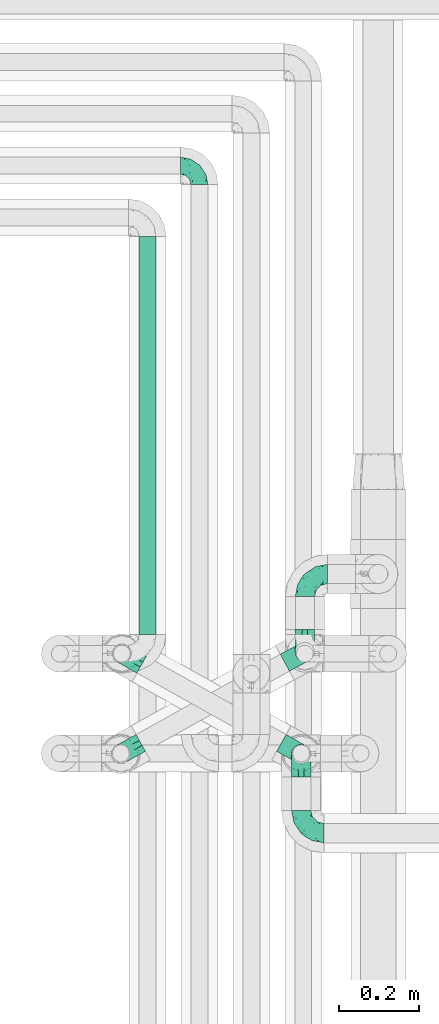
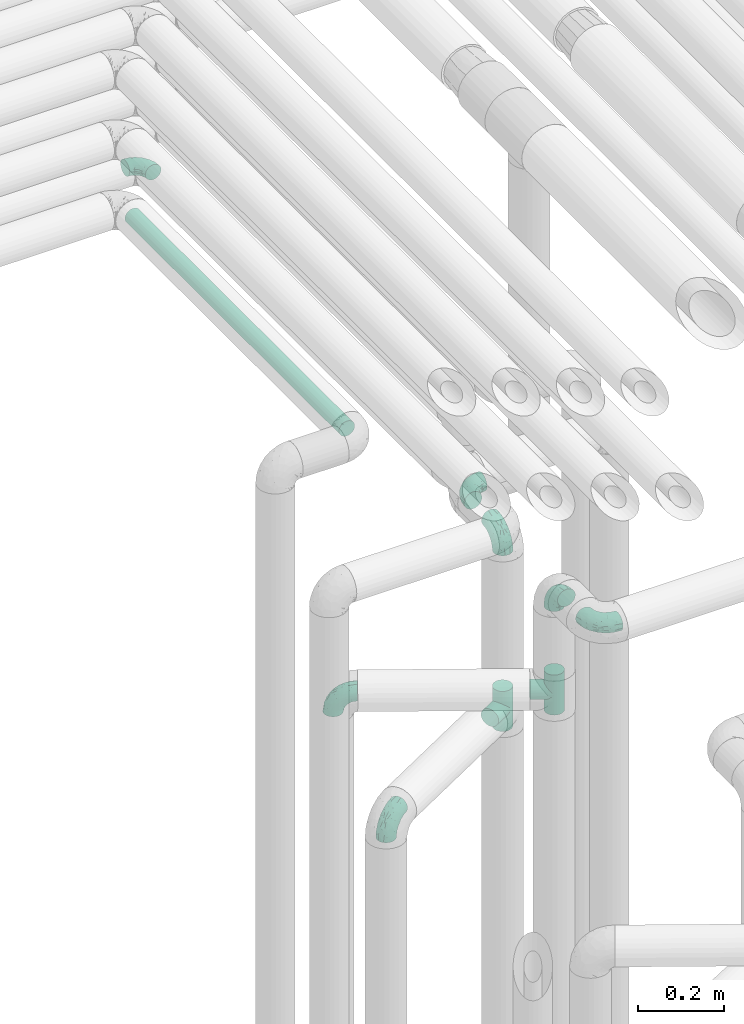
# One storey, part 602 of 827: 9 flow fittings, 1 flow segment.
"""IFC2X3 building model written with IfcOpenShell, lengths in millimetres."""

from ifc_helpers import new_model, entity, si_unit, converted_unit, derived_unit, direction, frame, origin, origin_2d_with_axis, place, context, subcontext, project, spatial, circle, extrude, faceted_brep, source, transform, mapped, material, type_object, type_shapes, element, save


model = new_model("IFC2X3")

# Units and contexts
model_context = context("Model", 3, precision=0.01, world=origin(), true_north=direction((6.12303176911189e-17, 1.0)))
body_context = subcontext(model_context, "Body", "Model", "MODEL_VIEW")
ifc_project = project(units=[si_unit("LENGTHUNIT", "METRE", prefix="MILLI"), si_unit("AREAUNIT", "SQUARE_METRE"), si_unit("VOLUMEUNIT", "CUBIC_METRE"), converted_unit("PLANEANGLEUNIT", "DEGREE", entity("IfcRatioMeasure", 0.0174532925199433), si_unit("PLANEANGLEUNIT", "RADIAN"), dimensions=[0, 0, 0, 0, 0, 0, 0]), si_unit("MASSUNIT", "GRAM", prefix="KILO"), derived_unit("MASSDENSITYUNIT", [(si_unit("MASSUNIT", "GRAM", prefix="KILO"), 1), (si_unit("LENGTHUNIT", "METRE"), -3)]), derived_unit("MOMENTOFINERTIAUNIT", [(si_unit("LENGTHUNIT", "METRE"), 4)]), si_unit("TIMEUNIT", "SECOND"), si_unit("FREQUENCYUNIT", "HERTZ"), si_unit("THERMODYNAMICTEMPERATUREUNIT", "DEGREE_CELSIUS"), derived_unit("THERMALTRANSMITTANCEUNIT", [(si_unit("MASSUNIT", "GRAM", prefix="KILO"), 1), (si_unit("THERMODYNAMICTEMPERATUREUNIT", "KELVIN"), -1), (si_unit("TIMEUNIT", "SECOND"), -3)]), derived_unit("VOLUMETRICFLOWRATEUNIT", [(si_unit("LENGTHUNIT", "METRE"), 3), (si_unit("TIMEUNIT", "SECOND"), -1)]), derived_unit("MASSFLOWRATEUNIT", [(si_unit("MASSUNIT", "GRAM", prefix="KILO"), 1), (si_unit("TIMEUNIT", "SECOND"), -1)]), derived_unit("ROTATIONALFREQUENCYUNIT", [(si_unit("TIMEUNIT", "SECOND"), -1)]), si_unit("ELECTRICCURRENTUNIT", "AMPERE"), si_unit("ELECTRICVOLTAGEUNIT", "VOLT"), si_unit("POWERUNIT", "WATT"), si_unit("FORCEUNIT", "NEWTON", prefix="KILO"), si_unit("ILLUMINANCEUNIT", "LUX"), si_unit("LUMINOUSFLUXUNIT", "LUMEN"), si_unit("LUMINOUSINTENSITYUNIT", "CANDELA"), derived_unit("USERDEFINED", [(si_unit("MASSUNIT", "GRAM", prefix="KILO"), -1), (si_unit("LENGTHUNIT", "METRE"), -2), (si_unit("TIMEUNIT", "SECOND"), 3), (si_unit("LUMINOUSFLUXUNIT", "LUMEN"), 1)]), derived_unit("LINEARVELOCITYUNIT", [(si_unit("LENGTHUNIT", "METRE"), 1), (si_unit("TIMEUNIT", "SECOND"), -1)]), si_unit("PRESSUREUNIT", "PASCAL"), derived_unit("USERDEFINED", [(si_unit("LENGTHUNIT", "METRE"), -2), (si_unit("MASSUNIT", "GRAM", prefix="KILO"), 1), (si_unit("TIMEUNIT", "SECOND"), -2)]), derived_unit("LINEARFORCEUNIT", [(si_unit("MASSUNIT", "GRAM", prefix="KILO"), 1), (si_unit("LENGTHUNIT", "METRE"), 1), (si_unit("TIMEUNIT", "SECOND"), -2), (si_unit("LENGTHUNIT", "METRE"), -1)]), derived_unit("PLANARFORCEUNIT", [(si_unit("MASSUNIT", "GRAM", prefix="KILO"), 1), (si_unit("LENGTHUNIT", "METRE"), 1), (si_unit("TIMEUNIT", "SECOND"), -2), (si_unit("LENGTHUNIT", "METRE"), -2)])], contexts=[model_context])

# Site, building, storey
site_placement = place(None, origin())
site = spatial("IfcSite", under=ifc_project, at=site_placement, CompositionType="ELEMENT")
building_placement = place(site_placement, origin())
building = spatial("IfcBuilding", under=site, at=building_placement, CompositionType="ELEMENT")
storey_placement = place(building_placement, frame((0.0, 0.0, 28200.0)))
storey = spatial("IfcBuildingStorey", under=building, at=storey_placement, Name="08", CompositionType="ELEMENT", Elevation=28200.0)

# Flow segment
pipe_segment_type = type_object("IfcPipeSegmentType", PredefinedType="NOTDEFINED")
flow_segment_placement = place(storey_placement, frame((35317.29, 13054.2, 2977.25)))
element("IfcFlowSegment", 1, at=flow_segment_placement, inside=storey, type_object=pipe_segment_type, context=body_context, shape_type="SweptSolid", body=[
    extrude(circle(Radius=21.15, at=origin_2d_with_axis()), frame((22.75, 0.0, 22.75), z_axis=(0.0, 1.0, 0.0), x_axis=(-1.0, 0.0, 0.0)), (0.0, 0.0, 1.0), 997.797074054168),
])

# Flow fittings
ifc_material = material()
pipe_fitting_type_1 = type_object("IfcPipeFittingType", Name="ADSK_1", PredefinedType="NOTDEFINED", material=ifc_material)
shared_shape_1 = source(origin(), body_context, "Body", "Brep", [
    faceted_brep([(-57.0, 12.07, -20.91), (-57.0, 6.25, -23.33), (-57.0, 0.0, -24.15), (-57.0, -6.25, -23.33), (-57.0, -12.08, -20.91), (-57.0, -17.08, -17.08), (-57.0, -20.91, -12.08), (-57.0, -23.33, -6.25), (-57.0, -24.15, 0.0), (-57.0, -23.33, 6.25), (-57.0, -20.91, 12.07), (-57.0, -17.08, 17.08), (-57.0, -12.08, 20.91), (-57.0, -6.25, 23.33), (-57.0, 0.0, 24.15), (-57.0, 6.25, 23.33), (-57.0, 12.07, 20.91), (-57.0, 17.08, 17.08), (-57.0, 20.91, 12.07), (-57.0, 23.33, 6.25), (-57.0, 24.15, 0.0), (-57.0, 23.33, -6.25), (-57.0, 20.91, -12.08), (-57.0, 17.08, -17.08), (0.0, 57.0, -24.15), (-6.25, 57.0, -23.33), (-12.07, 57.0, -20.91), (-17.08, 57.0, -17.08), (-20.91, 57.0, -12.08), (-23.33, 57.0, -6.25), (-24.15, 57.0, 0.0), (-23.33, 57.0, 6.25), (-20.91, 57.0, 12.07), (-17.08, 57.0, 17.08), (-12.07, 57.0, 20.91), (-6.25, 57.0, 23.33), (0.0, 57.0, 24.15), (6.25, 57.0, 23.33), (12.08, 57.0, 20.91), (17.08, 57.0, 17.08), (20.91, 57.0, 12.07), (23.33, 57.0, 6.25), (24.15, 57.0, 0.0), (23.33, 57.0, -6.25), (20.91, 57.0, -12.08), (17.08, 57.0, -17.08), (12.08, 57.0, -20.91), (6.25, 57.0, -23.33), (14.9, 21.14, 6.17), (13.61, 24.64, 12.48), (6.23, 8.95, 8.98), (-41.47, -21.06, 0.0), (-41.92, -18.38, 13.72), (-24.64, -13.61, 12.48), (-37.37, -13.24, 18.15), (-6.8, -4.93, 8.18), (-21.76, -15.19, 6.22), (-12.78, -9.18, 0.0), (-37.73, -20.51, 7.75), (-7.38, 7.38, 20.24), (-23.37, -4.26, 20.42), (-11.9, -3.19, 15.86), (-42.14, -8.7, 21.82), (13.24, 37.37, 18.15), (9.33, 23.53, 16.85), (4.26, 23.37, 20.42), (2.77, 10.92, 15.55), (-29.46, 0.91, 23.52), (-44.13, 20.56, 15.69), (-39.25, 26.33, 10.88), (-49.02, 22.92, 9.96), (-34.58, 23.87, 17.15), (-15.8, 6.8, 22.81), (-8.67, 20.47, 23.88), (-18.12, 12.9, 24.08), (-48.29, 14.92, 19.65), (-44.06, -2.85, 23.78), (-9.23, 48.95, 22.58), (-3.78, 42.74, 24.07), (-40.34, 4.26, 24.09), (-44.02, 26.14, 5.46), (-44.04, 9.88, 22.74), (-4.95, 16.87, 22.52), (-2.75, 1.43, 12.5), (-25.48, 40.98, 10.71), (20.51, 37.73, 7.75), (18.38, 41.92, 13.72), (8.7, 42.14, 21.82), (-25.95, -17.97, 0.0), (2.85, 44.06, 23.78), (21.06, 41.47, 0.0), (17.97, 25.95, 0.0), (-24.04, -9.27, 17.13), (-33.26, 33.26, 5.86), (-28.55, 40.57, 0.0), (-40.57, 28.55, 0.0), (-25.29, 47.19, 4.06), (-27.01, 31.1, 16.77), (-15.7, 43.95, 19.9), (-20.27, 45.22, 15.61), (-30.53, 31.98, 12.64), (-11.28, 38.33, 22.92), (-9.97, 27.88, 24.09), (-20.15, 30.26, 21.25), (-31.25, 11.75, 23.64), (-28.75, 7.23, 24.15), (-29.53, 18.06, 22.27), (-28.44, 24.21, 20.02), (-37.55, 17.7, 20.26), (-15.88, 29.25, 22.99), (-20.82, 20.82, 23.44), (-0.91, 29.46, 23.52), (-13.5, -7.67, 12.04), (1.49, 1.56, 5.16), (8.86, 10.35, 4.59), (0.38, -0.38, 0.0), (9.18, 12.78, 0.0), (-37.37, -13.24, -18.15), (8.86, 10.35, -4.59), (-45.22, 20.27, -15.61), (-43.95, 15.7, -19.9), (-38.33, 11.28, -22.92), (-48.95, 9.23, -22.58), (-47.19, 25.29, -4.06), (-33.26, 33.26, -5.86), (18.38, 41.92, -13.72), (-30.26, 20.15, -21.25), (2.85, 44.06, -23.78), (-4.26, 40.34, -24.09), (-40.98, 25.48, -10.71), (-41.92, -18.38, -13.72), (9.25, 23.5, -16.92), (4.26, 23.37, -20.42), (13.24, 37.37, -18.15), (-37.73, -20.51, -7.75), (-11.75, 31.25, -23.64), (-7.23, 28.75, -24.15), (-12.9, 18.12, -24.08), (8.7, 42.14, -21.82), (-44.06, -2.85, -23.78), (-6.8, 15.8, -22.81), (-20.47, 8.67, -23.88), (-24.64, -13.61, -12.48), (-42.74, 3.78, -24.07), (-18.06, 29.53, -22.27), (-24.21, 28.44, -20.02), (-27.88, 9.97, -24.09), (-31.1, 27.01, -16.77), (-26.14, 44.02, -5.46), (14.9, 21.14, -6.17), (20.51, 37.73, -7.75), (-9.88, 44.04, -22.74), (-20.56, 44.13, -15.69), (-21.76, -15.19, -6.22), (-13.5, -7.67, -12.04), (-24.14, -9.76, -16.74), (-11.9, -3.19, -15.86), (-14.92, 48.29, -19.65), (-23.37, -4.26, -20.42), (-0.91, 29.46, -23.52), (-26.33, 39.25, -10.88), (-23.87, 34.58, -17.15), (-42.14, -8.7, -21.82), (-22.92, 49.02, -9.96), (13.61, 24.64, -12.48), (-31.98, 30.53, -12.64), (-16.87, 4.95, -22.52), (-17.7, 37.55, -20.26), (-29.25, 15.88, -22.99), (-20.82, 20.82, -23.44), (-29.46, 0.91, -23.52), (-7.38, 7.38, -20.24), (2.77, 10.92, -15.55), (6.23, 8.95, -8.98), (-6.8, -4.93, -8.18), (-2.81, 1.41, -12.54), (1.49, 1.56, -5.16)], [[[0, 1, 2, 3, 4, 5, 6, 7, 8, 9, 10, 11, 12, 13, 14, 15, 16, 17, 18, 19, 20, 21, 22, 23]], [[24, 25, 26, 27, 28, 29, 30, 31, 32, 33, 34, 35, 36, 37, 38, 39, 40, 41, 42, 43, 44, 45, 46, 47]], [[48, 49, 50]], [[9, 8, 51]], [[52, 53, 54]], [[55, 56, 57]], [[10, 58, 52]], [[9, 58, 10]], [[59, 60, 61]], [[54, 12, 11]], [[54, 62, 12]], [[63, 39, 38]], [[64, 65, 66]], [[62, 60, 67]], [[68, 69, 70]], [[71, 69, 68]], [[72, 73, 74]], [[16, 75, 17]], [[13, 76, 14]], [[35, 77, 78]], [[14, 79, 15]], [[17, 68, 18]], [[14, 76, 79]], [[20, 19, 80]], [[70, 19, 18]], [[81, 15, 79]], [[15, 81, 16]], [[73, 72, 82]], [[66, 83, 50]], [[32, 31, 84]], [[85, 86, 49]], [[63, 87, 65]], [[56, 58, 88]], [[36, 89, 37]], [[85, 41, 40]], [[36, 35, 78]], [[90, 41, 85]], [[40, 39, 86]], [[12, 62, 13]], [[86, 85, 40]], [[48, 85, 49]], [[85, 91, 90]], [[87, 38, 37]], [[92, 60, 54]], [[80, 69, 93]], [[93, 94, 95]], [[10, 52, 11]], [[94, 96, 30]], [[97, 98, 99]], [[80, 93, 95]], [[100, 97, 84]], [[99, 98, 33]], [[101, 102, 78]], [[103, 101, 98]], [[96, 31, 30]], [[77, 98, 101]], [[77, 35, 34]], [[34, 33, 98]], [[9, 51, 58]], [[87, 63, 38]], [[104, 105, 74]], [[106, 103, 107]], [[106, 81, 104]], [[75, 68, 17]], [[108, 107, 71]], [[33, 32, 99]], [[109, 103, 110]], [[101, 109, 102]], [[89, 78, 111]], [[53, 52, 58]], [[54, 11, 52]], [[60, 62, 54]], [[88, 58, 51]], [[76, 62, 67]], [[53, 112, 92]], [[60, 59, 72]], [[39, 63, 86]], [[49, 86, 63]], [[89, 87, 37]], [[42, 41, 90]], [[111, 82, 65]], [[111, 65, 87]], [[65, 59, 66]], [[104, 81, 79]], [[75, 81, 108]], [[32, 84, 99]], [[97, 99, 84]], [[98, 97, 103]], [[106, 107, 108]], [[74, 102, 110]], [[111, 78, 102]], [[74, 110, 104]], [[74, 67, 72]], [[61, 92, 112]], [[66, 59, 61]], [[56, 53, 58]], [[66, 50, 49]], [[61, 112, 83]], [[66, 49, 64]], [[78, 89, 36]], [[87, 89, 111]], [[62, 76, 13]], [[79, 76, 67]], [[100, 93, 69]], [[96, 93, 84]], [[55, 113, 50]], [[113, 114, 50]], [[104, 79, 105]], [[106, 104, 110]], [[20, 80, 95]], [[85, 48, 91]], [[115, 114, 113]], [[116, 91, 48]], [[70, 80, 19]], [[93, 96, 94]], [[84, 31, 96]], [[103, 106, 110]], [[81, 106, 108]], [[103, 97, 107]], [[71, 107, 97]], [[71, 97, 100]], [[108, 71, 68]], [[79, 67, 105]], [[67, 74, 105]], [[115, 113, 57]], [[112, 56, 55]], [[56, 88, 57]], [[60, 72, 67]], [[82, 72, 59]], [[65, 82, 59]], [[82, 111, 73]], [[111, 102, 73]], [[102, 74, 73]], [[81, 75, 16]], [[68, 75, 108]], [[68, 70, 18]], [[80, 70, 69]], [[98, 77, 34]], [[78, 77, 101]], [[93, 100, 84]], [[71, 100, 69]], [[102, 109, 110]], [[101, 103, 109]], [[53, 92, 54]], [[61, 60, 92]], [[56, 112, 53]], [[83, 112, 55]], [[50, 83, 55]], [[61, 83, 66]], [[49, 63, 64]], [[65, 64, 63]], [[57, 113, 55]], [[114, 115, 116]], [[116, 48, 114]], [[48, 50, 114]], [[117, 5, 4]], [[116, 115, 118]], [[119, 120, 23]], [[121, 122, 120]], [[95, 123, 20]], [[0, 23, 120]], [[124, 95, 94]], [[125, 45, 44]], [[121, 120, 126]], [[24, 127, 128]], [[22, 21, 129]], [[0, 122, 1]], [[5, 117, 130]], [[131, 132, 133]], [[134, 88, 51]], [[135, 136, 137]], [[6, 5, 130]], [[46, 138, 47]], [[139, 3, 2]], [[140, 141, 137]], [[6, 134, 7]], [[134, 130, 142]], [[143, 2, 1]], [[144, 126, 145]], [[121, 146, 143]], [[147, 120, 119]], [[94, 148, 124]], [[149, 150, 91]], [[30, 29, 148]], [[151, 25, 128]], [[27, 152, 28]], [[134, 153, 88]], [[154, 155, 156]], [[27, 26, 157]], [[151, 26, 25]], [[155, 158, 156]], [[24, 47, 127]], [[1, 122, 143]], [[138, 132, 159]], [[160, 152, 161]], [[24, 128, 25]], [[46, 133, 138]], [[162, 117, 4]], [[148, 160, 124]], [[152, 160, 163]], [[154, 142, 155]], [[45, 125, 133]], [[133, 46, 45]], [[125, 164, 133]], [[51, 7, 134]], [[42, 90, 43]], [[165, 147, 129]], [[153, 134, 142]], [[43, 150, 44]], [[162, 4, 3]], [[141, 140, 166]], [[117, 162, 158]], [[163, 29, 28]], [[43, 90, 150]], [[123, 21, 20]], [[144, 151, 135]], [[157, 152, 27]], [[167, 145, 161]], [[23, 22, 119]], [[168, 126, 169]], [[121, 168, 146]], [[139, 143, 170]], [[142, 130, 117]], [[8, 7, 51]], [[134, 6, 130]], [[139, 162, 3]], [[170, 166, 158]], [[170, 158, 162]], [[158, 171, 156]], [[44, 150, 125]], [[91, 150, 90]], [[164, 125, 150]], [[132, 138, 133]], [[127, 138, 159]], [[131, 164, 172]], [[132, 171, 140]], [[135, 151, 128]], [[157, 151, 167]], [[22, 129, 119]], [[147, 119, 129]], [[120, 147, 126]], [[144, 145, 167]], [[137, 146, 169]], [[170, 143, 146]], [[137, 169, 135]], [[137, 159, 140]], [[171, 172, 156]], [[173, 174, 175]], [[156, 175, 154]], [[174, 57, 153]], [[132, 172, 171]], [[172, 164, 173]], [[143, 139, 2]], [[162, 139, 170]], [[138, 127, 47]], [[128, 127, 159]], [[165, 124, 160]], [[123, 124, 129]], [[149, 173, 164]], [[176, 174, 173]], [[135, 128, 136]], [[144, 135, 169]], [[150, 149, 164]], [[176, 118, 115]], [[149, 91, 116]], [[30, 148, 94]], [[163, 148, 29]], [[124, 123, 95]], [[129, 21, 123]], [[126, 144, 169]], [[151, 144, 167]], [[126, 147, 145]], [[161, 145, 147]], [[161, 147, 165]], [[167, 161, 152]], [[128, 159, 136]], [[159, 137, 136]], [[154, 153, 142]], [[132, 140, 159]], [[174, 176, 57]], [[57, 88, 153]], [[166, 140, 171]], [[158, 166, 171]], [[166, 170, 141]], [[170, 146, 141]], [[146, 137, 141]], [[151, 157, 26]], [[152, 157, 167]], [[152, 163, 28]], [[148, 163, 160]], [[120, 122, 0]], [[143, 122, 121]], [[124, 165, 129]], [[161, 165, 160]], [[146, 168, 169]], [[121, 126, 168]], [[142, 117, 155]], [[158, 155, 117]], [[175, 156, 172]], [[153, 154, 174]], [[173, 175, 172]], [[174, 154, 175]], [[164, 131, 133]], [[172, 132, 131]], [[176, 173, 118]], [[57, 176, 115]], [[173, 149, 118]], [[149, 116, 118]]]),
])
type_shapes(pipe_fitting_type_1, [shared_shape_1])
for number, where, z_axis, x_axis, name in (
    (2, (35734.24, 13010.49, 2600.0), (-1.0, 0.0, 0.0), (0.0, 0.0, 1.0), "ADSK_1"),
    (3, (35734.24, 13206.08, 2600.0), (0.0, 0.0, 1.0), (-1.0, 0.0, 0.0), "ADSK_1"),
    (4, (35725.03, 12754.46, 2600.0), (1.0, 0.0, 0.0), (0.0, 0.0, 1.0), "ADSK_1"),
    (5, (35725.03, 12556.08, 2600.0), (0.0, 0.0, 1.0), (0.0, -1.0, 0.0), "ADSK_1"),
    (6, (35275.34, 13006.53, 2305.0), (-0.488239231862421, -0.872709832917215, 0.0), (-0.872709832917215, 0.488239231862421, 0.0), "ADSK_1"),
    (7, (35272.9, 12754.86, 2100.0), (0.486104408033654, -0.873900740639491, 0.0), (-0.873900740639491, -0.486104408033654, 0.0), "ADSK_1"),
):
    element("IfcFlowFitting", number, at=place(storey_placement, frame(where, z_axis=z_axis, x_axis=x_axis)), inside=storey, type_object=pipe_fitting_type_1, material=ifc_material, Name=name, ObjectType="ADSK_1", context=body_context, shape_type="MappedRepresentation", body=[
        mapped(shared_shape_1, transform((0.0, 0.0, 0.0), scale=1.0)),
    ])
pipe_fitting_type_2 = type_object("IfcPipeFittingType", Name="ADSK_1", PredefinedType="NOTDEFINED", material=ifc_material)
shared_shape_2 = source(origin(), body_context, "Body", "Brep", [
    faceted_brep([(-48.0, 10.6, -18.36), (-48.0, 5.49, -20.48), (-48.0, 0.0, -21.2), (-48.0, -5.49, -20.48), (-48.0, -10.6, -18.36), (-48.0, -14.99, -14.99), (-48.0, -18.36, -10.6), (-48.0, -20.48, -5.49), (-48.0, -21.2, 0.0), (-48.0, -20.48, 5.49), (-48.0, -18.36, 10.6), (-48.0, -14.99, 14.99), (-48.0, -10.6, 18.36), (-48.0, -5.49, 20.48), (-48.0, 0.0, 21.2), (-48.0, 5.49, 20.48), (-48.0, 10.6, 18.36), (-48.0, 14.99, 14.99), (-48.0, 18.36, 10.6), (-48.0, 20.48, 5.49), (-48.0, 21.2, 0.0), (-48.0, 20.48, -5.49), (-48.0, 18.36, -10.6), (-48.0, 14.99, -14.99), (0.0, 48.0, -21.2), (-5.49, 48.0, -20.48), (-10.6, 48.0, -18.36), (-14.99, 48.0, -14.99), (-18.36, 48.0, -10.6), (-20.48, 48.0, -5.49), (-21.2, 48.0, 0.0), (-20.48, 48.0, 5.49), (-18.36, 48.0, 10.6), (-14.99, 48.0, 14.99), (-10.6, 48.0, 18.36), (-5.49, 48.0, 20.48), (0.0, 48.0, 21.2), (5.49, 48.0, 20.48), (10.6, 48.0, 18.36), (14.99, 48.0, 14.99), (18.36, 48.0, 10.6), (20.48, 48.0, 5.49), (21.2, 48.0, 0.0), (20.48, 48.0, -5.49), (18.36, 48.0, -10.6), (14.99, 48.0, -14.99), (10.6, 48.0, -18.36), (5.49, 48.0, -20.48), (-35.25, -16.22, 12.01), (-34.76, -18.57, 0.0), (-20.87, -12.37, 10.9), (-31.49, -11.78, 15.9), (-37.0, -2.58, 20.86), (-33.89, 3.62, 21.15), (-31.81, -18.14, 6.76), (-5.78, 5.78, 17.67), (-19.42, -4.1, 17.86), (-9.6, -3.39, 13.73), (-35.44, -7.73, 19.13), (11.78, 31.49, 15.9), (-5.93, -5.46, 6.95), (-18.45, -13.78, 5.46), (-10.29, -8.43, 0.0), (-24.6, 0.55, 20.62), (-37.28, 17.94, 13.81), (-33.38, 22.85, 9.59), (-41.46, 20.06, 8.75), (-29.51, 20.45, 15.16), (-15.04, 10.79, 21.13), (-7.08, 16.98, 20.93), (-8.39, 23.51, 21.15), (-40.86, 13.03, 17.26), (-8.05, 41.26, 19.83), (-3.21, 35.97, 21.14), (8.53, 19.66, 14.74), (4.1, 19.42, 17.86), (-37.72, 22.66, 4.78), (-37.07, 8.58, 19.98), (-13.0, 5.43, 19.97), (-3.78, 13.93, 19.7), (3.02, 8.69, 13.43), (-2.27, -0.05, 10.65), (6.22, 6.99, 7.09), (-22.25, 34.6, 9.45), (18.14, 31.81, 6.76), (16.22, 35.25, 12.01), (12.37, 20.87, 10.9), (7.73, 35.44, 19.13), (-21.52, -15.93, 0.0), (2.58, 37.0, 20.86), (18.57, 34.76, 0.0), (13.78, 18.45, 5.46), (15.93, 21.52, 0.0), (-20.03, -8.54, 14.9), (-28.6, 28.6, 5.16), (-24.79, 34.6, 0.0), (-34.6, 24.79, 0.0), (-22.81, 37.41, 4.68), (-23.36, 26.33, 14.79), (-13.68, 37.05, 17.49), (-17.72, 38.12, 13.73), (-26.25, 27.3, 11.24), (-9.71, 32.34, 20.14), (-17.26, 25.6, 18.71), (-26.33, 9.99, 20.77), (-24.06, 6.05, 21.2), (-25.02, 15.46, 19.56), (-24.3, 20.72, 17.57), (-31.95, 15.23, 17.8), (-13.53, 24.7, 20.21), (-17.6, 17.6, 20.6), (-0.55, 24.6, 20.62), (-11.41, -7.48, 10.43), (0.93, -0.93, 0.0), (8.43, 10.29, 0.0), (-11.41, -7.48, -10.43), (-20.1, -8.84, -14.66), (-9.6, -3.39, -13.73), (7.73, 35.44, -19.13), (4.1, 19.42, -17.86), (-0.55, 24.6, -20.62), (-38.12, 17.72, -13.73), (-37.05, 13.68, -17.49), (-32.34, 9.71, -20.14), (-41.26, 8.05, -19.83), (-37.41, 22.81, -4.68), (-23.51, 8.39, -21.15), (-35.97, 3.21, -21.14), (-28.6, 28.6, -5.16), (-31.81, -18.14, -6.76), (-18.45, -13.78, -5.46), (-25.6, 17.26, -18.71), (-19.42, -4.1, -17.86), (-17.94, 37.28, -13.81), (-22.85, 33.38, -9.59), (-20.06, 41.46, -8.75), (-31.49, -11.78, -15.9), (-35.25, -16.22, -12.01), (8.53, 19.66, -14.74), (11.78, 31.49, -15.9), (-9.99, 26.33, -20.77), (-6.05, 24.06, -21.2), (-10.79, 15.04, -21.13), (-37.0, -2.58, -20.86), (-16.98, 7.08, -20.93), (-5.43, 13.0, -19.97), (-13.93, 3.78, -19.7), (-20.87, -12.37, -10.9), (-26.33, 23.36, -14.79), (-22.66, 37.72, -4.78), (13.78, 18.45, -5.46), (18.14, 31.81, -6.76), (-15.46, 25.02, -19.56), (-20.72, 24.3, -17.57), (16.22, 35.25, -12.01), (-13.03, 40.86, -17.26), (-8.58, 37.07, -19.98), (2.58, 37.0, -20.86), (-3.62, 33.89, -21.15), (-34.6, 22.25, -9.45), (6.22, 6.99, -7.09), (-20.45, 29.51, -15.16), (-35.44, -7.73, -19.13), (12.37, 20.87, -10.9), (-27.3, 26.25, -11.24), (-15.23, 31.95, -17.8), (-24.7, 13.53, -20.21), (-24.6, 0.55, -20.62), (-5.78, 5.78, -17.67), (-17.6, 17.6, -20.6), (3.02, 8.69, -13.43), (-5.93, -5.46, -6.95), (-2.27, -0.05, -10.65)], [[[0, 1, 2, 3, 4, 5, 6, 7, 8, 9, 10, 11, 12, 13, 14, 15, 16, 17, 18, 19, 20, 21, 22, 23]], [[24, 25, 26, 27, 28, 29, 30, 31, 32, 33, 34, 35, 36, 37, 38, 39, 40, 41, 42, 43, 44, 45, 46, 47]], [[10, 48, 11]], [[9, 8, 49]], [[48, 50, 51]], [[14, 52, 53]], [[10, 54, 48]], [[9, 54, 10]], [[55, 56, 57]], [[51, 12, 11]], [[51, 58, 12]], [[59, 39, 38]], [[60, 61, 62]], [[58, 56, 63]], [[64, 65, 66]], [[67, 65, 64]], [[68, 69, 70]], [[16, 71, 17]], [[13, 52, 14]], [[35, 72, 73]], [[14, 53, 15]], [[17, 64, 18]], [[74, 59, 75]], [[20, 19, 76]], [[66, 19, 18]], [[77, 15, 53]], [[15, 77, 16]], [[69, 78, 79]], [[80, 81, 82]], [[32, 31, 83]], [[84, 85, 86]], [[59, 87, 75]], [[61, 54, 88]], [[36, 89, 37]], [[84, 41, 40]], [[36, 35, 73]], [[90, 41, 84]], [[40, 39, 85]], [[12, 58, 13]], [[85, 84, 40]], [[91, 84, 86]], [[84, 92, 90]], [[87, 38, 37]], [[93, 56, 51]], [[65, 94, 76]], [[94, 95, 96]], [[84, 91, 92]], [[95, 97, 30]], [[98, 99, 100]], [[76, 94, 96]], [[101, 98, 83]], [[100, 99, 33]], [[102, 70, 73]], [[103, 102, 99]], [[94, 97, 95]], [[72, 99, 102]], [[72, 35, 34]], [[34, 33, 99]], [[9, 49, 54]], [[87, 59, 38]], [[104, 105, 68]], [[106, 103, 107]], [[106, 77, 104]], [[71, 64, 17]], [[108, 107, 67]], [[33, 32, 100]], [[109, 103, 110]], [[102, 109, 70]], [[89, 73, 111]], [[50, 48, 54]], [[51, 11, 48]], [[56, 58, 51]], [[88, 54, 49]], [[52, 58, 63]], [[50, 112, 93]], [[56, 55, 78]], [[39, 59, 85]], [[86, 85, 59]], [[89, 87, 37]], [[42, 41, 90]], [[111, 79, 75]], [[111, 75, 87]], [[75, 55, 80]], [[104, 77, 53]], [[71, 77, 108]], [[32, 83, 100]], [[98, 100, 83]], [[99, 98, 103]], [[106, 107, 108]], [[68, 70, 110]], [[111, 73, 70]], [[68, 110, 104]], [[68, 63, 78]], [[57, 93, 112]], [[80, 55, 57]], [[61, 50, 54]], [[80, 82, 86]], [[81, 57, 112]], [[74, 86, 59]], [[60, 113, 82]], [[82, 114, 91]], [[101, 94, 65]], [[97, 94, 83]], [[73, 89, 36]], [[87, 89, 111]], [[58, 52, 13]], [[53, 52, 63]], [[104, 53, 105]], [[106, 104, 110]], [[20, 76, 96]], [[76, 19, 66]], [[103, 106, 110]], [[77, 106, 108]], [[103, 98, 107]], [[67, 107, 98]], [[67, 98, 101]], [[108, 67, 64]], [[53, 63, 105]], [[63, 68, 105]], [[83, 31, 97]], [[30, 97, 31]], [[62, 113, 60]], [[112, 61, 60]], [[61, 88, 62]], [[86, 82, 91]], [[56, 78, 63]], [[114, 82, 113]], [[114, 92, 91]], [[79, 78, 55]], [[75, 79, 55]], [[69, 79, 111]], [[70, 69, 111]], [[78, 69, 68]], [[77, 71, 16]], [[64, 71, 108]], [[64, 66, 18]], [[76, 66, 65]], [[99, 72, 34]], [[73, 72, 102]], [[94, 101, 83]], [[67, 101, 65]], [[75, 80, 74]], [[80, 86, 74]], [[70, 109, 110]], [[102, 103, 109]], [[50, 93, 51]], [[57, 56, 93]], [[61, 112, 50]], [[81, 112, 60]], [[82, 81, 60]], [[80, 57, 81]], [[115, 116, 117]], [[118, 119, 120]], [[121, 122, 23]], [[123, 124, 122]], [[96, 125, 20]], [[123, 126, 127]], [[128, 96, 95]], [[129, 130, 88]], [[123, 122, 131]], [[116, 132, 117]], [[133, 134, 135]], [[0, 124, 1]], [[5, 136, 137]], [[138, 119, 139]], [[129, 88, 49]], [[140, 141, 142]], [[6, 5, 137]], [[46, 118, 47]], [[143, 3, 2]], [[144, 145, 146]], [[6, 129, 7]], [[129, 137, 147]], [[127, 2, 1]], [[148, 122, 121]], [[128, 125, 96]], [[134, 128, 149]], [[95, 149, 128]], [[150, 151, 92]], [[30, 29, 149]], [[152, 131, 153]], [[27, 133, 28]], [[154, 45, 44]], [[136, 5, 4]], [[27, 26, 155]], [[156, 26, 25]], [[24, 157, 158]], [[24, 47, 157]], [[22, 21, 159]], [[160, 150, 114]], [[134, 133, 161]], [[142, 144, 126]], [[46, 139, 118]], [[162, 136, 4]], [[156, 25, 158]], [[1, 124, 127]], [[115, 147, 116]], [[45, 154, 139]], [[139, 46, 45]], [[154, 163, 139]], [[162, 4, 3]], [[42, 90, 43]], [[130, 129, 147]], [[49, 7, 129]], [[43, 151, 44]], [[0, 23, 122]], [[24, 158, 25]], [[136, 162, 132]], [[135, 29, 28]], [[43, 90, 151]], [[164, 148, 159]], [[152, 156, 140]], [[155, 133, 27]], [[165, 153, 161]], [[23, 22, 121]], [[123, 131, 166]], [[123, 166, 126]], [[143, 127, 167]], [[147, 137, 136]], [[8, 7, 49]], [[129, 6, 137]], [[143, 162, 3]], [[167, 146, 132]], [[167, 132, 162]], [[132, 168, 117]], [[44, 151, 154]], [[92, 151, 90]], [[163, 154, 151]], [[119, 118, 139]], [[157, 118, 120]], [[138, 139, 163]], [[119, 168, 145]], [[140, 156, 158]], [[155, 156, 165]], [[22, 159, 121]], [[148, 121, 159]], [[122, 148, 131]], [[152, 153, 165]], [[142, 126, 169]], [[167, 127, 126]], [[142, 169, 140]], [[142, 120, 145]], [[168, 170, 117]], [[160, 171, 172]], [[115, 172, 171]], [[171, 62, 130]], [[119, 170, 168]], [[170, 163, 160]], [[150, 163, 151]], [[113, 171, 160]], [[164, 128, 134]], [[125, 128, 159]], [[127, 143, 2]], [[162, 143, 167]], [[118, 157, 47]], [[158, 157, 120]], [[140, 158, 141]], [[152, 140, 169]], [[30, 149, 95]], [[149, 29, 135]], [[131, 152, 169]], [[156, 152, 165]], [[131, 148, 153]], [[161, 153, 148]], [[161, 148, 164]], [[165, 161, 133]], [[158, 120, 141]], [[120, 142, 141]], [[159, 21, 125]], [[20, 125, 21]], [[115, 130, 147]], [[114, 113, 160]], [[62, 171, 113]], [[62, 88, 130]], [[160, 163, 150]], [[150, 92, 114]], [[119, 145, 120]], [[146, 145, 168]], [[132, 146, 168]], [[144, 146, 167]], [[126, 144, 167]], [[145, 144, 142]], [[156, 155, 26]], [[133, 155, 165]], [[133, 135, 28]], [[149, 135, 134]], [[122, 124, 0]], [[127, 124, 123]], [[128, 164, 159]], [[161, 164, 134]], [[163, 170, 138]], [[170, 119, 138]], [[131, 169, 166]], [[126, 166, 169]], [[147, 136, 116]], [[132, 116, 136]], [[172, 115, 117]], [[130, 115, 171]], [[117, 170, 172]], [[160, 172, 170]]]),
])
type_shapes(pipe_fitting_type_2, [shared_shape_2])
flow_fitting_placement = place(storey_placement, frame((35470.03, 14230.0, 3000.0), z_axis=(0.0, 0.0, 1.0), x_axis=(0.0, 1.0, 0.0)))
element("IfcFlowFitting", 8, at=flow_fitting_placement, inside=storey, type_object=pipe_fitting_type_2, material=ifc_material, Name="ADSK_1", ObjectType="ADSK_1", context=body_context, shape_type="MappedRepresentation", body=[
    mapped(shared_shape_2, transform((0.0, 0.0, 0.0), scale=1.0)),
])
pipe_fitting_type_3 = type_object("IfcPipeFittingType", Name="ADSK_1", PredefinedType="NOTDEFINED", material=ifc_material)
shared_shape_3 = source(origin(), body_context, "Body", "Brep", [
    faceted_brep([(-57.0, 12.07, -20.91), (-57.0, 6.25, -23.33), (-57.0, 0.0, -24.15), (-57.0, -6.25, -23.33), (-57.0, -12.08, -20.91), (-57.0, -17.08, -17.08), (-57.0, -20.91, -12.08), (-57.0, -23.33, -6.25), (-57.0, -24.15, 0.0), (-57.0, -23.33, 6.25), (-57.0, -20.91, 12.07), (-57.0, -17.08, 17.08), (-57.0, -12.08, 20.91), (-57.0, -6.25, 23.33), (-57.0, 0.0, 24.15), (-57.0, 6.25, 23.33), (-57.0, 12.07, 20.91), (-57.0, 17.08, 17.08), (-57.0, 20.91, 12.07), (-57.0, 23.33, 6.25), (-57.0, 24.15, 0.0), (-57.0, 23.33, -6.25), (-57.0, 20.91, -12.08), (-57.0, 17.08, -17.08), (57.0, 0.0, -24.15), (57.0, 6.25, -23.33), (57.0, 12.07, -20.91), (57.0, 17.08, -17.08), (57.0, 20.91, -12.08), (57.0, 23.33, -6.25), (57.0, 24.15, 0.0), (57.0, 23.33, 6.25), (57.0, 20.91, 12.07), (57.0, 17.08, 17.08), (57.0, 12.07, 20.91), (57.0, 6.25, 23.33), (57.0, 0.0, 24.15), (57.0, -6.25, 23.33), (57.0, -12.08, 20.91), (57.0, -17.08, 17.08), (57.0, -20.91, 12.07), (57.0, -23.33, 6.25), (57.0, -24.15, 0.0), (57.0, -23.33, -6.25), (57.0, -20.91, -12.08), (57.0, -17.08, -17.08), (57.0, -12.08, -20.91), (57.0, -6.25, -23.33), (23.27, -23.27, 6.45), (24.15, -24.15, 0.0), (-24.15, -24.15, 0.0), (20.9, -20.9, 12.1), (13.54, -13.54, 20.0), (17.52, -17.52, 16.62), (-23.27, -23.27, 6.45), (-20.9, -20.9, 12.1), (-17.52, -17.52, 16.62), (-13.54, -13.54, 20.0), (-9.19, -9.19, 22.33), (9.19, -9.19, 22.33), (4.64, -4.64, 23.7), (0.0, 0.0, 24.15), (-4.64, -4.64, 23.7), (4.64, -4.64, -23.7), (0.0, 0.0, -24.15), (-4.64, -4.64, -23.7), (-9.19, -9.19, -22.33), (9.19, -9.19, -22.33), (13.54, -13.54, -20.0), (17.52, -17.52, -16.62), (20.9, -20.9, -12.1), (23.27, -23.27, -6.45), (-13.54, -13.54, -20.0), (-17.52, -17.52, -16.62), (-23.27, -23.27, -6.45), (-20.9, -20.9, -12.1), (0.0, -57.0, -24.15), (6.25, -57.0, -23.33), (12.08, -57.0, -20.91), (17.08, -57.0, -17.08), (20.91, -57.0, -12.08), (23.33, -57.0, -6.25), (24.15, -57.0, 0.0), (23.33, -57.0, 6.25), (20.91, -57.0, 12.07), (17.08, -57.0, 17.08), (12.08, -57.0, 20.91), (6.25, -57.0, 23.33), (0.0, -57.0, 24.15), (-6.25, -57.0, 23.33), (-12.07, -57.0, 20.91), (-17.08, -57.0, 17.08), (-20.91, -57.0, 12.07), (-23.33, -57.0, 6.25), (-24.15, -57.0, 0.0), (-23.33, -57.0, -6.25), (-20.91, -57.0, -12.08), (-17.08, -57.0, -17.08), (-12.07, -57.0, -20.91), (-6.25, -57.0, -23.33)], [[[0, 1, 2, 3, 4, 5, 6, 7, 8, 9, 10, 11, 12, 13, 14, 15, 16, 17, 18, 19, 20, 21, 22, 23]], [[24, 25, 26, 27, 28, 29, 30, 31, 32, 33, 34, 35, 36, 37, 38, 39, 40, 41, 42, 43, 44, 45, 46, 47]], [[41, 40, 48]], [[42, 41, 49]], [[50, 9, 8]], [[49, 41, 48]], [[40, 51, 48]], [[39, 38, 52]], [[51, 40, 53]], [[52, 53, 39]], [[53, 40, 39]], [[50, 54, 9]], [[9, 54, 10]], [[54, 55, 10]], [[56, 57, 11]], [[11, 10, 56]], [[11, 57, 12]], [[56, 10, 55]], [[12, 57, 58]], [[52, 38, 59]], [[60, 36, 61]], [[62, 61, 14]], [[59, 37, 60]], [[37, 59, 38]], [[60, 37, 36]], [[61, 36, 35, 15, 14]], [[32, 31, 19, 18]], [[17, 16, 34, 33]], [[18, 17, 33, 32]], [[35, 34, 16, 15]], [[20, 19, 31, 30]], [[62, 13, 58]], [[13, 62, 14]], [[58, 13, 12]], [[27, 23, 22, 28]], [[22, 21, 29, 28]], [[0, 23, 27, 26]], [[20, 30, 29, 21]], [[24, 47, 63]], [[24, 64, 2, 1, 25]], [[64, 24, 63]], [[2, 64, 65]], [[26, 25, 1, 0]], [[65, 66, 3]], [[2, 65, 3]], [[66, 4, 3]], [[63, 47, 67]], [[46, 45, 68]], [[69, 68, 45]], [[44, 70, 69]], [[69, 45, 44]], [[46, 68, 67]], [[43, 42, 49]], [[7, 50, 8]], [[43, 71, 44]], [[71, 43, 49]], [[44, 71, 70]], [[72, 4, 66]], [[72, 5, 4]], [[5, 72, 73]], [[5, 73, 6]], [[74, 50, 7]], [[75, 74, 6]], [[74, 7, 6]], [[75, 6, 73]], [[46, 67, 47]], [[76, 77, 78, 79, 80, 81, 82, 83, 84, 85, 86, 87, 88, 89, 90, 91, 92, 93, 94, 95, 96, 97, 98, 99]], [[50, 94, 93]], [[54, 50, 93]], [[91, 90, 57]], [[56, 92, 91]], [[54, 93, 92]], [[58, 90, 89]], [[55, 54, 92]], [[56, 55, 92]], [[58, 57, 90]], [[88, 61, 62]], [[58, 89, 62]], [[56, 91, 57]], [[62, 89, 88]], [[60, 88, 87]], [[86, 59, 87]], [[84, 83, 48]], [[53, 85, 84]], [[52, 86, 85]], [[49, 83, 82]], [[59, 60, 87]], [[52, 59, 86]], [[49, 48, 83]], [[51, 53, 84]], [[48, 51, 84]], [[52, 85, 53]], [[88, 60, 61]], [[82, 81, 49]], [[71, 49, 81]], [[69, 80, 79]], [[79, 78, 68]], [[71, 81, 80]], [[67, 78, 77]], [[70, 71, 80]], [[69, 70, 80]], [[67, 68, 78]], [[76, 64, 63]], [[67, 77, 63]], [[69, 79, 68]], [[63, 77, 76]], [[65, 76, 99]], [[98, 66, 99]], [[96, 95, 74]], [[73, 97, 96]], [[72, 98, 97]], [[50, 95, 94]], [[66, 65, 99]], [[72, 66, 98]], [[50, 74, 95]], [[75, 73, 96]], [[74, 75, 96]], [[72, 97, 73]], [[76, 65, 64]]]),
])
type_shapes(pipe_fitting_type_3, [shared_shape_3])
for number, where, z_axis, x_axis, name in (
    (9, (35725.03, 12754.46, 2305.0), (0.494757339901246, 0.869031170104872, 0.0), (0.0, 0.0, 1.0), "ADSK_1"),
    (10, (35734.14, 13010.68, 2100.0), (-0.476176251027639, 0.879349860952547, 0.0), (0.0, 0.0, 1.0), "ADSK_1"),
):
    element("IfcFlowFitting", number, at=place(storey_placement, frame(where, z_axis=z_axis, x_axis=x_axis)), inside=storey, type_object=pipe_fitting_type_3, material=ifc_material, Name=name, ObjectType="ADSK_1", context=body_context, shape_type="MappedRepresentation", body=[
        mapped(shared_shape_3, transform((0.0, 0.0, 0.0), scale=1.0)),
    ])

save(model, "model.ifc")
